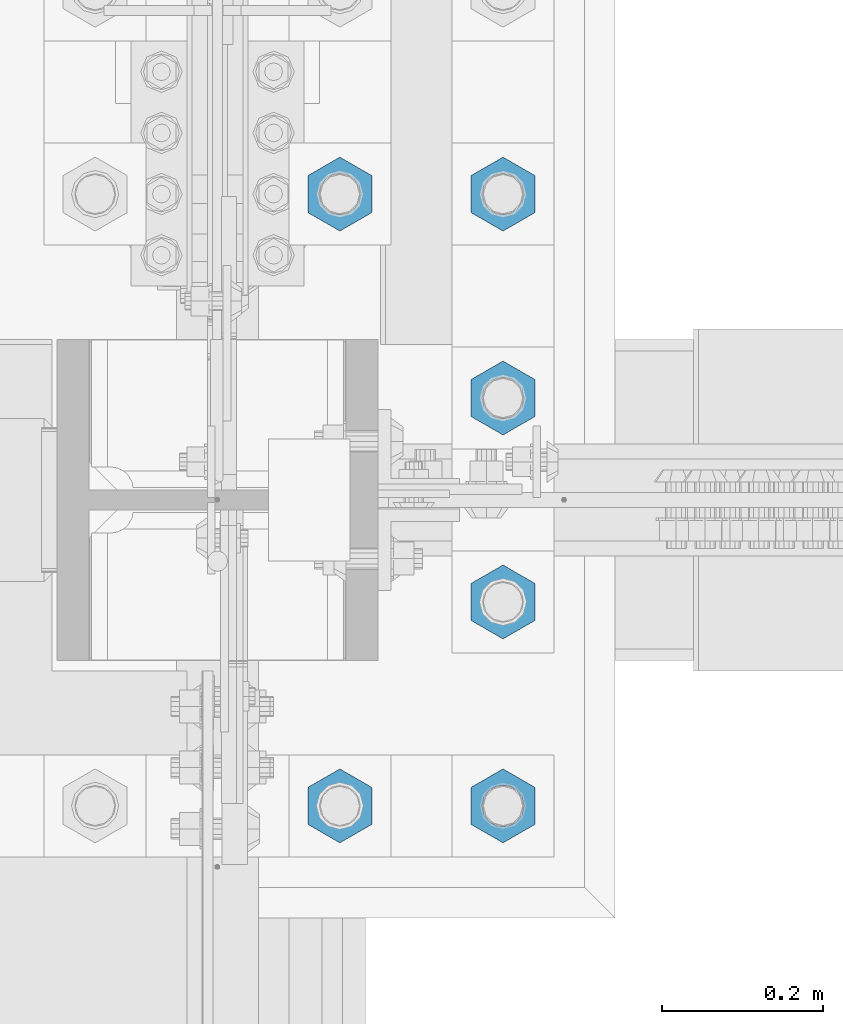
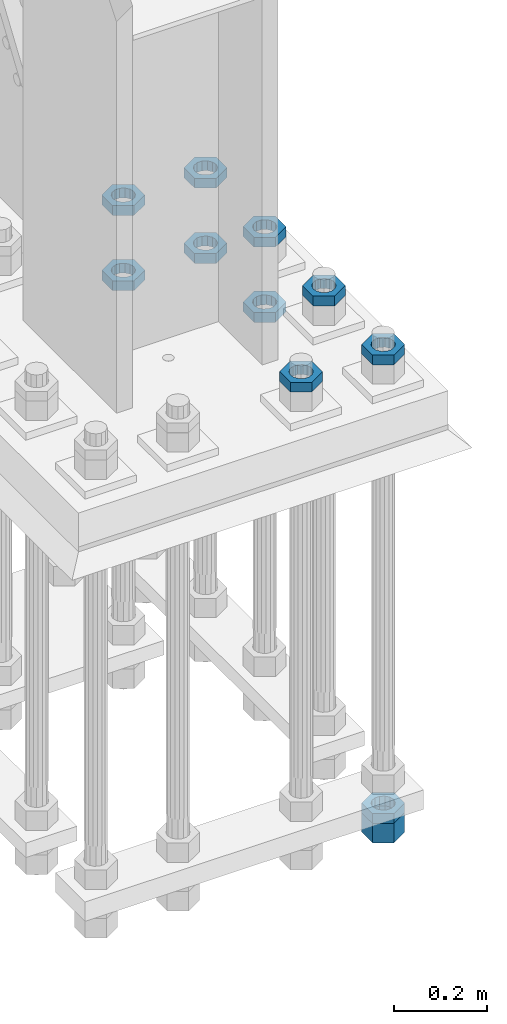
# One storey, part 2368 of 3843: 11 beams, 1 element without a shape of its own.
"""IFC2X3 building model written with IfcOpenShell, lengths in millimetres."""

from ifc_helpers import new_model, si_unit, frame, origin_with_axes, place, context, subcontext, project, spatial, faceted_brep, material, type_object, element, aggregate, save


model = new_model("IFC2X3")

# Units and contexts
model_context = context("Model", 3, precision=1e-05, world=origin_with_axes())
body_context = subcontext(model_context, "Body", "Model", "MODEL_VIEW")
ifc_project = project(units=[si_unit("LENGTHUNIT", "METRE", prefix="MILLI"), si_unit("AREAUNIT", "SQUARE_METRE"), si_unit("VOLUMEUNIT", "CUBIC_METRE"), si_unit("MASSUNIT", "GRAM", prefix="KILO"), si_unit("TIMEUNIT", "SECOND"), si_unit("PLANEANGLEUNIT", "RADIAN"), si_unit("SOLIDANGLEUNIT", "STERADIAN"), si_unit("THERMODYNAMICTEMPERATUREUNIT", "DEGREE_CELSIUS"), si_unit("LUMINOUSINTENSITYUNIT", "LUMEN")], contexts=[model_context])

# Site, building, storey
site_placement = place(None, origin_with_axes())
site = spatial("IfcSite", under=ifc_project, at=site_placement, CompositionType="ELEMENT")
building_placement = place(site_placement, origin_with_axes())
building = spatial("IfcBuilding", under=site, at=building_placement, Name="Undefined", CompositionType="ELEMENT")
storey_placement = place(building_placement, origin_with_axes())
storey = spatial("IfcBuildingStorey", under=building, at=storey_placement, Name="Undefined", CompositionType="ELEMENT", Elevation=0.0)

# Assembly, beams
assembly_placement = place(storey_placement, origin_with_axes())
assembly = element("IfcElementAssembly", 1, at=assembly_placement, inside=storey, Name="TEMPLATE", AssemblyPlace="NOTDEFINED", PredefinedType="RIGID_FRAME")
ifc_material = material(Name="STEEL/A572-50")
beam_type_1 = type_object("IfcBeamType", Name="2_HALF_NUT", PredefinedType="NOTDEFINED")
beam_1_placement = place(assembly_placement, frame((36931.6, 67398.9, 30060.9), z_axis=(-1.0, 0.0, 0.0), x_axis=(0.0, 0.0, -1.0)))
beam_1 = element("IfcBeam", 2, at=beam_1_placement, type_object=beam_type_1, material=ifc_material, Name="NUT", ObjectType="2_HALF_NUT", context=body_context, shape_type="Brep", body=[
    faceted_brep([(0.0, -46.0369987487793, 0.0), (0.0, -23.0184993743896, -39.869213104248), (25.4000000000015, -23.0184993743896, -39.869213104248), (25.4000000000015, -46.0369987487793, 0.0), (0.0, 23.0184993743896, -39.869213104248), (25.4000000000015, 23.0184993743896, -39.869213104248), (0.0, 46.0369987487793, 0.0), (25.4000000000015, 46.0369987487793, 0.0), (0.0, 23.0184993743896, 39.869213104248), (25.4000000000015, 23.0184993743896, 39.869213104248), (0.0, -23.0184993743896, 39.869213104248), (25.4000000000015, -23.0184993743896, 39.869213104248), (0.0, 0.0, 26.1940002441406), (0.0, 11.3650617044477, 23.5999013092805), (25.4000000000015, 11.3650617044477, 23.5999013092805), (25.4000000000015, 0.0, 26.1940002441406), (0.0, 20.4791109456419, 16.3316083006721), (25.4000000000015, 20.4791109456419, 16.3316083006721), (0.0, 25.5370200498292, 5.82867859874386), (25.4000000000015, 25.5370200498292, 5.82867859874386), (0.0, 25.5370200498292, -5.82867859874386), (25.4000000000015, 25.5370200498292, -5.82867859874386), (0.0, 20.4791109456419, -16.3316083006721), (25.4000000000015, 20.4791109456419, -16.3316083006721), (0.0, 11.3650617044477, -23.5999013092805), (25.4000000000015, 11.3650617044477, -23.5999013092805), (0.0, 0.0, -26.1940002441406), (25.4000000000015, 0.0, -26.1940002441406), (0.0, -11.3650617044477, -23.5999013092805), (25.4000000000015, -11.3650617044477, -23.5999013092805), (0.0, -20.4791109456419, -16.3316083006721), (25.4000000000015, -20.4791109456419, -16.3316083006721), (0.0, -25.5370200498292, -5.82867859874386), (25.4000000000015, -25.5370200498292, -5.82867859874386), (0.0, -25.5370200498292, 5.82867859874386), (25.4000000000015, -25.5370200498292, 5.82867859874386), (0.0, -20.4791109456419, 16.3316083006721), (25.4000000000015, -20.4791109456419, 16.3316083006721), (0.0, -11.3650617044477, 23.5999013092805), (25.4000000000015, -11.3650617044477, 23.5999013092805)], [[[0, 1, 2, 3]], [[1, 4, 5, 2]], [[4, 6, 7, 5]], [[6, 8, 9, 7]], [[8, 10, 11, 9]], [[10, 0, 3, 11]], [[12, 13, 14, 15]], [[13, 16, 17, 14]], [[16, 18, 19, 17]], [[18, 20, 21, 19]], [[20, 22, 23, 21]], [[22, 24, 25, 23]], [[24, 26, 27, 25]], [[26, 28, 29, 27]], [[28, 30, 31, 29]], [[30, 32, 33, 31]], [[32, 34, 35, 33]], [[34, 36, 37, 35]], [[36, 38, 39, 37]], [[38, 12, 15, 39]], [[5, 7, 9, 11, 3, 2], [17, 19, 21, 23, 25, 27, 29, 31, 33, 35, 37, 39, 15, 14]], [[10, 8, 6, 4, 1, 0], [38, 36, 34, 32, 30, 28, 26, 24, 22, 20, 18, 16, 13, 12]]]),
])
beam_2_placement = place(assembly_placement, frame((36931.6, 67652.9, 30060.9), z_axis=(1.0, 0.0, 0.0), x_axis=(0.0, 0.0, -1.0)))
beam_2 = element("IfcBeam", 3, at=beam_2_placement, type_object=beam_type_1, material=ifc_material, Name="NUT", ObjectType="2_HALF_NUT", context=body_context, shape_type="Brep", body=[
    faceted_brep([(0.0, -46.0369987487793, 0.0), (0.0, -23.0184993743896, -39.869213104248), (25.4000000000015, -23.0184993743896, -39.869213104248), (25.4000000000015, -46.0369987487793, 0.0), (0.0, 23.0184993743896, -39.869213104248), (25.4000000000015, 23.0184993743896, -39.869213104248), (0.0, 46.0369987487793, 0.0), (25.4000000000015, 46.0369987487793, 0.0), (0.0, 23.0184993743896, 39.869213104248), (25.4000000000015, 23.0184993743896, 39.869213104248), (0.0, -23.0184993743896, 39.869213104248), (25.4000000000015, -23.0184993743896, 39.869213104248), (0.0, 0.0, 26.1940002441406), (0.0, 11.3650617044477, 23.5999013092805), (25.4000000000015, 11.3650617044477, 23.5999013092805), (25.4000000000015, 0.0, 26.1940002441406), (0.0, 20.4791109456419, 16.3316083006721), (25.4000000000015, 20.4791109456419, 16.3316083006721), (0.0, 25.5370200498292, 5.82867859874386), (25.4000000000015, 25.5370200498292, 5.82867859874386), (0.0, 25.5370200498292, -5.82867859874386), (25.4000000000015, 25.5370200498292, -5.82867859874386), (0.0, 20.4791109456419, -16.3316083006721), (25.4000000000015, 20.4791109456419, -16.3316083006721), (0.0, 11.3650617044477, -23.5999013092805), (25.4000000000015, 11.3650617044477, -23.5999013092805), (0.0, 0.0, -26.1940002441406), (25.4000000000015, 0.0, -26.1940002441406), (0.0, -11.3650617044477, -23.5999013092805), (25.4000000000015, -11.3650617044477, -23.5999013092805), (0.0, -20.4791109456419, -16.3316083006721), (25.4000000000015, -20.4791109456419, -16.3316083006721), (0.0, -25.5370200498292, -5.82867859874386), (25.4000000000015, -25.5370200498292, -5.82867859874386), (0.0, -25.5370200498292, 5.82867859874386), (25.4000000000015, -25.5370200498292, 5.82867859874386), (0.0, -20.4791109456419, 16.3316083006721), (25.4000000000015, -20.4791109456419, 16.3316083006721), (0.0, -11.3650617044477, 23.5999013092805), (25.4000000000015, -11.3650617044477, 23.5999013092805)], [[[0, 1, 2, 3]], [[1, 4, 5, 2]], [[4, 6, 7, 5]], [[6, 8, 9, 7]], [[8, 10, 11, 9]], [[10, 0, 3, 11]], [[12, 13, 14, 15]], [[13, 16, 17, 14]], [[16, 18, 19, 17]], [[18, 20, 21, 19]], [[20, 22, 23, 21]], [[22, 24, 25, 23]], [[24, 26, 27, 25]], [[26, 28, 29, 27]], [[28, 30, 31, 29]], [[30, 32, 33, 31]], [[32, 34, 35, 33]], [[34, 36, 37, 35]], [[36, 38, 39, 37]], [[38, 12, 15, 39]], [[5, 7, 9, 11, 3, 2], [17, 19, 21, 23, 25, 27, 29, 31, 33, 35, 37, 39, 15, 14]], [[10, 8, 6, 4, 1, 0], [38, 36, 34, 32, 30, 28, 26, 24, 22, 20, 18, 16, 13, 12]]]),
])
beam_3_placement = place(assembly_placement, frame((36728.4, 67652.9, 30060.9), z_axis=(1.0, 0.0, 0.0), x_axis=(0.0, 0.0, -1.0)))
beam_3 = element("IfcBeam", 4, at=beam_3_placement, type_object=beam_type_1, material=ifc_material, Name="NUT", ObjectType="2_HALF_NUT", context=body_context, shape_type="Brep", body=[
    faceted_brep([(0.0, -46.0369987487793, 0.0), (0.0, -23.0184993743896, -39.869213104248), (25.4000000000015, -23.0184993743896, -39.869213104248), (25.4000000000015, -46.0369987487793, 0.0), (0.0, 23.0184993743896, -39.869213104248), (25.4000000000015, 23.0184993743896, -39.869213104248), (0.0, 46.0369987487793, 0.0), (25.4000000000015, 46.0369987487793, 0.0), (0.0, 23.0184993743896, 39.869213104248), (25.4000000000015, 23.0184993743896, 39.869213104248), (0.0, -23.0184993743896, 39.869213104248), (25.4000000000015, -23.0184993743896, 39.869213104248), (0.0, 0.0, 26.1940002441406), (0.0, 11.3650617044477, 23.5999013092805), (25.4000000000015, 11.3650617044477, 23.5999013092805), (25.4000000000015, 0.0, 26.1940002441406), (0.0, 20.4791109456419, 16.3316083006721), (25.4000000000015, 20.4791109456419, 16.3316083006721), (0.0, 25.5370200498292, 5.82867859874386), (25.4000000000015, 25.5370200498292, 5.82867859874386), (0.0, 25.5370200498292, -5.82867859874386), (25.4000000000015, 25.5370200498292, -5.82867859874386), (0.0, 20.4791109456419, -16.3316083006721), (25.4000000000015, 20.4791109456419, -16.3316083006721), (0.0, 11.3650617044477, -23.5999013092805), (25.4000000000015, 11.3650617044477, -23.5999013092805), (0.0, 0.0, -26.1940002441406), (25.4000000000015, 0.0, -26.1940002441406), (0.0, -11.3650617044477, -23.5999013092805), (25.4000000000015, -11.3650617044477, -23.5999013092805), (0.0, -20.4791109456419, -16.3316083006721), (25.4000000000015, -20.4791109456419, -16.3316083006721), (0.0, -25.5370200498292, -5.82867859874386), (25.4000000000015, -25.5370200498292, -5.82867859874386), (0.0, -25.5370200498292, 5.82867859874386), (25.4000000000015, -25.5370200498292, 5.82867859874386), (0.0, -20.4791109456419, 16.3316083006721), (25.4000000000015, -20.4791109456419, 16.3316083006721), (0.0, -11.3650617044477, 23.5999013092805), (25.4000000000015, -11.3650617044477, 23.5999013092805)], [[[0, 1, 2, 3]], [[1, 4, 5, 2]], [[4, 6, 7, 5]], [[6, 8, 9, 7]], [[8, 10, 11, 9]], [[10, 0, 3, 11]], [[12, 13, 14, 15]], [[13, 16, 17, 14]], [[16, 18, 19, 17]], [[18, 20, 21, 19]], [[20, 22, 23, 21]], [[22, 24, 25, 23]], [[24, 26, 27, 25]], [[26, 28, 29, 27]], [[28, 30, 31, 29]], [[30, 32, 33, 31]], [[32, 34, 35, 33]], [[34, 36, 37, 35]], [[36, 38, 39, 37]], [[38, 12, 15, 39]], [[5, 7, 9, 11, 3, 2], [17, 19, 21, 23, 25, 27, 29, 31, 33, 35, 37, 39, 15, 14]], [[10, 8, 6, 4, 1, 0], [38, 36, 34, 32, 30, 28, 26, 24, 22, 20, 18, 16, 13, 12]]]),
])
beam_4_placement = place(assembly_placement, frame((36931.6, 67398.9, 30257.75), z_axis=(1.0, 0.0, 0.0), x_axis=(0.0, 0.0, -1.0)))
beam_4 = element("IfcBeam", 5, at=beam_4_placement, type_object=beam_type_1, material=ifc_material, Name="NUT", ObjectType="2_HALF_NUT", context=body_context, shape_type="Brep", body=[
    faceted_brep([(0.0, -46.0369987487793, 0.0), (0.0, -23.0184993743896, -39.869213104248), (25.4000000000015, -23.0184993743896, -39.869213104248), (25.4000000000015, -46.0369987487793, 0.0), (0.0, 23.0184993743896, -39.869213104248), (25.4000000000015, 23.0184993743896, -39.869213104248), (0.0, 46.0369987487793, 0.0), (25.4000000000015, 46.0369987487793, 0.0), (0.0, 23.0184993743896, 39.869213104248), (25.4000000000015, 23.0184993743896, 39.869213104248), (0.0, -23.0184993743896, 39.869213104248), (25.4000000000015, -23.0184993743896, 39.869213104248), (0.0, 0.0, 26.1940002441406), (0.0, 11.3650617044477, 23.5999013092805), (25.4000000000015, 11.3650617044477, 23.5999013092805), (25.4000000000015, 0.0, 26.1940002441406), (0.0, 20.4791109456419, 16.3316083006721), (25.4000000000015, 20.4791109456419, 16.3316083006721), (0.0, 25.5370200498292, 5.82867859874386), (25.4000000000015, 25.5370200498292, 5.82867859874386), (0.0, 25.5370200498292, -5.82867859874386), (25.4000000000015, 25.5370200498292, -5.82867859874386), (0.0, 20.4791109456419, -16.3316083006721), (25.4000000000015, 20.4791109456419, -16.3316083006721), (0.0, 11.3650617044477, -23.5999013092805), (25.4000000000015, 11.3650617044477, -23.5999013092805), (0.0, 0.0, -26.1940002441406), (25.4000000000015, 0.0, -26.1940002441406), (0.0, -11.3650617044477, -23.5999013092805), (25.4000000000015, -11.3650617044477, -23.5999013092805), (0.0, -20.4791109456419, -16.3316083006721), (25.4000000000015, -20.4791109456419, -16.3316083006721), (0.0, -25.5370200498292, -5.82867859874386), (25.4000000000015, -25.5370200498292, -5.82867859874386), (0.0, -25.5370200498292, 5.82867859874386), (25.4000000000015, -25.5370200498292, 5.82867859874386), (0.0, -20.4791109456419, 16.3316083006721), (25.4000000000015, -20.4791109456419, 16.3316083006721), (0.0, -11.3650617044477, 23.5999013092805), (25.4000000000015, -11.3650617044477, 23.5999013092805)], [[[0, 1, 2, 3]], [[1, 4, 5, 2]], [[4, 6, 7, 5]], [[6, 8, 9, 7]], [[8, 10, 11, 9]], [[10, 0, 3, 11]], [[12, 13, 14, 15]], [[13, 16, 17, 14]], [[16, 18, 19, 17]], [[18, 20, 21, 19]], [[20, 22, 23, 21]], [[22, 24, 25, 23]], [[24, 26, 27, 25]], [[26, 28, 29, 27]], [[28, 30, 31, 29]], [[30, 32, 33, 31]], [[32, 34, 35, 33]], [[34, 36, 37, 35]], [[36, 38, 39, 37]], [[38, 12, 15, 39]], [[5, 7, 9, 11, 3, 2], [17, 19, 21, 23, 25, 27, 29, 31, 33, 35, 37, 39, 15, 14]], [[10, 8, 6, 4, 1, 0], [38, 36, 34, 32, 30, 28, 26, 24, 22, 20, 18, 16, 13, 12]]]),
])
beam_5_placement = place(assembly_placement, frame((36931.6, 67144.9, 30257.75), z_axis=(1.0, 0.0, 0.0), x_axis=(0.0, 0.0, -1.0)))
beam_5 = element("IfcBeam", 6, at=beam_5_placement, type_object=beam_type_1, material=ifc_material, Name="NUT", ObjectType="2_HALF_NUT", context=body_context, shape_type="Brep", body=[
    faceted_brep([(0.0, -46.0369987487793, 0.0), (0.0, -23.0184993743896, -39.869213104248), (25.4000000000015, -23.0184993743896, -39.869213104248), (25.4000000000015, -46.0369987487793, 0.0), (0.0, 23.0184993743896, -39.869213104248), (25.4000000000015, 23.0184993743896, -39.869213104248), (0.0, 46.0369987487793, 0.0), (25.4000000000015, 46.0369987487793, 0.0), (0.0, 23.0184993743896, 39.869213104248), (25.4000000000015, 23.0184993743896, 39.869213104248), (0.0, -23.0184993743896, 39.869213104248), (25.4000000000015, -23.0184993743896, 39.869213104248), (0.0, 0.0, 26.1940002441406), (0.0, 11.3650617044477, 23.5999013092805), (25.4000000000015, 11.3650617044477, 23.5999013092805), (25.4000000000015, 0.0, 26.1940002441406), (0.0, 20.4791109456419, 16.3316083006721), (25.4000000000015, 20.4791109456419, 16.3316083006721), (0.0, 25.5370200498292, 5.82867859874386), (25.4000000000015, 25.5370200498292, 5.82867859874386), (0.0, 25.5370200498292, -5.82867859874386), (25.4000000000015, 25.5370200498292, -5.82867859874386), (0.0, 20.4791109456419, -16.3316083006721), (25.4000000000015, 20.4791109456419, -16.3316083006721), (0.0, 11.3650617044477, -23.5999013092805), (25.4000000000015, 11.3650617044477, -23.5999013092805), (0.0, 0.0, -26.1940002441406), (25.4000000000015, 0.0, -26.1940002441406), (0.0, -11.3650617044477, -23.5999013092805), (25.4000000000015, -11.3650617044477, -23.5999013092805), (0.0, -20.4791109456419, -16.3316083006721), (25.4000000000015, -20.4791109456419, -16.3316083006721), (0.0, -25.5370200498292, -5.82867859874386), (25.4000000000015, -25.5370200498292, -5.82867859874386), (0.0, -25.5370200498292, 5.82867859874386), (25.4000000000015, -25.5370200498292, 5.82867859874386), (0.0, -20.4791109456419, 16.3316083006721), (25.4000000000015, -20.4791109456419, 16.3316083006721), (0.0, -11.3650617044477, 23.5999013092805), (25.4000000000015, -11.3650617044477, 23.5999013092805)], [[[0, 1, 2, 3]], [[1, 4, 5, 2]], [[4, 6, 7, 5]], [[6, 8, 9, 7]], [[8, 10, 11, 9]], [[10, 0, 3, 11]], [[12, 13, 14, 15]], [[13, 16, 17, 14]], [[16, 18, 19, 17]], [[18, 20, 21, 19]], [[20, 22, 23, 21]], [[22, 24, 25, 23]], [[24, 26, 27, 25]], [[26, 28, 29, 27]], [[28, 30, 31, 29]], [[30, 32, 33, 31]], [[32, 34, 35, 33]], [[34, 36, 37, 35]], [[36, 38, 39, 37]], [[38, 12, 15, 39]], [[5, 7, 9, 11, 3, 2], [17, 19, 21, 23, 25, 27, 29, 31, 33, 35, 37, 39, 15, 14]], [[10, 8, 6, 4, 1, 0], [38, 36, 34, 32, 30, 28, 26, 24, 22, 20, 18, 16, 13, 12]]]),
])
beam_6_placement = place(assembly_placement, frame((36728.4, 67652.9, 30257.75), z_axis=(-1.0, 0.0, 0.0), x_axis=(0.0, 0.0, -1.0)))
beam_6 = element("IfcBeam", 7, at=beam_6_placement, type_object=beam_type_1, material=ifc_material, Name="NUT", ObjectType="2_HALF_NUT", context=body_context, shape_type="Brep", body=[
    faceted_brep([(0.0, -46.0369987487793, 0.0), (0.0, -23.0184993743896, -39.869213104248), (25.4000000000015, -23.0184993743896, -39.869213104248), (25.4000000000015, -46.0369987487793, 0.0), (0.0, 23.0184993743896, -39.869213104248), (25.4000000000015, 23.0184993743896, -39.869213104248), (0.0, 46.0369987487793, 0.0), (25.4000000000015, 46.0369987487793, 0.0), (0.0, 23.0184993743896, 39.869213104248), (25.4000000000015, 23.0184993743896, 39.869213104248), (0.0, -23.0184993743896, 39.869213104248), (25.4000000000015, -23.0184993743896, 39.869213104248), (0.0, 0.0, 26.1940002441406), (0.0, 11.3650617044477, 23.5999013092805), (25.4000000000015, 11.3650617044477, 23.5999013092805), (25.4000000000015, 0.0, 26.1940002441406), (0.0, 20.4791109456419, 16.3316083006721), (25.4000000000015, 20.4791109456419, 16.3316083006721), (0.0, 25.5370200498292, 5.82867859874386), (25.4000000000015, 25.5370200498292, 5.82867859874386), (0.0, 25.5370200498292, -5.82867859874386), (25.4000000000015, 25.5370200498292, -5.82867859874386), (0.0, 20.4791109456419, -16.3316083006721), (25.4000000000015, 20.4791109456419, -16.3316083006721), (0.0, 11.3650617044477, -23.5999013092805), (25.4000000000015, 11.3650617044477, -23.5999013092805), (0.0, 0.0, -26.1940002441406), (25.4000000000015, 0.0, -26.1940002441406), (0.0, -11.3650617044477, -23.5999013092805), (25.4000000000015, -11.3650617044477, -23.5999013092805), (0.0, -20.4791109456419, -16.3316083006721), (25.4000000000015, -20.4791109456419, -16.3316083006721), (0.0, -25.5370200498292, -5.82867859874386), (25.4000000000015, -25.5370200498292, -5.82867859874386), (0.0, -25.5370200498292, 5.82867859874386), (25.4000000000015, -25.5370200498292, 5.82867859874386), (0.0, -20.4791109456419, 16.3316083006721), (25.4000000000015, -20.4791109456419, 16.3316083006721), (0.0, -11.3650617044477, 23.5999013092805), (25.4000000000015, -11.3650617044477, 23.5999013092805)], [[[0, 1, 2, 3]], [[1, 4, 5, 2]], [[4, 6, 7, 5]], [[6, 8, 9, 7]], [[8, 10, 11, 9]], [[10, 0, 3, 11]], [[12, 13, 14, 15]], [[13, 16, 17, 14]], [[16, 18, 19, 17]], [[18, 20, 21, 19]], [[20, 22, 23, 21]], [[22, 24, 25, 23]], [[24, 26, 27, 25]], [[26, 28, 29, 27]], [[28, 30, 31, 29]], [[30, 32, 33, 31]], [[32, 34, 35, 33]], [[34, 36, 37, 35]], [[36, 38, 39, 37]], [[38, 12, 15, 39]], [[5, 7, 9, 11, 3, 2], [17, 19, 21, 23, 25, 27, 29, 31, 33, 35, 37, 39, 15, 14]], [[10, 8, 6, 4, 1, 0], [38, 36, 34, 32, 30, 28, 26, 24, 22, 20, 18, 16, 13, 12]]]),
])
beam_7_placement = place(assembly_placement, frame((36931.6, 67652.9, 30257.75), z_axis=(-1.0, 0.0, 0.0), x_axis=(0.0, 0.0, -1.0)))
beam_7 = element("IfcBeam", 8, at=beam_7_placement, type_object=beam_type_1, material=ifc_material, Name="NUT", ObjectType="2_HALF_NUT", context=body_context, shape_type="Brep", body=[
    faceted_brep([(0.0, -46.0369987487793, 0.0), (0.0, -23.0184993743896, -39.869213104248), (25.4000000000015, -23.0184993743896, -39.869213104248), (25.4000000000015, -46.0369987487793, 0.0), (0.0, 23.0184993743896, -39.869213104248), (25.4000000000015, 23.0184993743896, -39.869213104248), (0.0, 46.0369987487793, 0.0), (25.4000000000015, 46.0369987487793, 0.0), (0.0, 23.0184993743896, 39.869213104248), (25.4000000000015, 23.0184993743896, 39.869213104248), (0.0, -23.0184993743896, 39.869213104248), (25.4000000000015, -23.0184993743896, 39.869213104248), (0.0, 0.0, 26.1940002441406), (0.0, 11.3650617044477, 23.5999013092805), (25.4000000000015, 11.3650617044477, 23.5999013092805), (25.4000000000015, 0.0, 26.1940002441406), (0.0, 20.4791109456419, 16.3316083006721), (25.4000000000015, 20.4791109456419, 16.3316083006721), (0.0, 25.5370200498292, 5.82867859874386), (25.4000000000015, 25.5370200498292, 5.82867859874386), (0.0, 25.5370200498292, -5.82867859874386), (25.4000000000015, 25.5370200498292, -5.82867859874386), (0.0, 20.4791109456419, -16.3316083006721), (25.4000000000015, 20.4791109456419, -16.3316083006721), (0.0, 11.3650617044477, -23.5999013092805), (25.4000000000015, 11.3650617044477, -23.5999013092805), (0.0, 0.0, -26.1940002441406), (25.4000000000015, 0.0, -26.1940002441406), (0.0, -11.3650617044477, -23.5999013092805), (25.4000000000015, -11.3650617044477, -23.5999013092805), (0.0, -20.4791109456419, -16.3316083006721), (25.4000000000015, -20.4791109456419, -16.3316083006721), (0.0, -25.5370200498292, -5.82867859874386), (25.4000000000015, -25.5370200498292, -5.82867859874386), (0.0, -25.5370200498292, 5.82867859874386), (25.4000000000015, -25.5370200498292, 5.82867859874386), (0.0, -20.4791109456419, 16.3316083006721), (25.4000000000015, -20.4791109456419, 16.3316083006721), (0.0, -11.3650617044477, 23.5999013092805), (25.4000000000015, -11.3650617044477, 23.5999013092805)], [[[0, 1, 2, 3]], [[1, 4, 5, 2]], [[4, 6, 7, 5]], [[6, 8, 9, 7]], [[8, 10, 11, 9]], [[10, 0, 3, 11]], [[12, 13, 14, 15]], [[13, 16, 17, 14]], [[16, 18, 19, 17]], [[18, 20, 21, 19]], [[20, 22, 23, 21]], [[22, 24, 25, 23]], [[24, 26, 27, 25]], [[26, 28, 29, 27]], [[28, 30, 31, 29]], [[30, 32, 33, 31]], [[32, 34, 35, 33]], [[34, 36, 37, 35]], [[36, 38, 39, 37]], [[38, 12, 15, 39]], [[5, 7, 9, 11, 3, 2], [17, 19, 21, 23, 25, 27, 29, 31, 33, 35, 37, 39, 15, 14]], [[10, 8, 6, 4, 1, 0], [38, 36, 34, 32, 30, 28, 26, 24, 22, 20, 18, 16, 13, 12]]]),
])
beam_8_placement = place(assembly_placement, frame((36728.4, 66890.9, 30257.75), z_axis=(1.0, 0.0, 0.0), x_axis=(0.0, 0.0, -1.0)))
beam_8 = element("IfcBeam", 9, at=beam_8_placement, type_object=beam_type_1, material=ifc_material, Name="NUT", ObjectType="2_HALF_NUT", context=body_context, shape_type="Brep", body=[
    faceted_brep([(0.0, -46.0369987487793, 0.0), (0.0, -23.0184993743896, -39.869213104248), (25.4000000000015, -23.0184993743896, -39.869213104248), (25.4000000000015, -46.0369987487793, 0.0), (0.0, 23.0184993743896, -39.869213104248), (25.4000000000015, 23.0184993743896, -39.869213104248), (0.0, 46.0369987487793, 0.0), (25.4000000000015, 46.0369987487793, 0.0), (0.0, 23.0184993743896, 39.869213104248), (25.4000000000015, 23.0184993743896, 39.869213104248), (0.0, -23.0184993743896, 39.869213104248), (25.4000000000015, -23.0184993743896, 39.869213104248), (0.0, 0.0, 26.1940002441406), (0.0, 11.3650617044477, 23.5999013092805), (25.4000000000015, 11.3650617044477, 23.5999013092805), (25.4000000000015, 0.0, 26.1940002441406), (0.0, 20.4791109456419, 16.3316083006721), (25.4000000000015, 20.4791109456419, 16.3316083006721), (0.0, 25.5370200498292, 5.82867859874386), (25.4000000000015, 25.5370200498292, 5.82867859874386), (0.0, 25.5370200498292, -5.82867859874386), (25.4000000000015, 25.5370200498292, -5.82867859874386), (0.0, 20.4791109456419, -16.3316083006721), (25.4000000000015, 20.4791109456419, -16.3316083006721), (0.0, 11.3650617044477, -23.5999013092805), (25.4000000000015, 11.3650617044477, -23.5999013092805), (0.0, 0.0, -26.1940002441406), (25.4000000000015, 0.0, -26.1940002441406), (0.0, -11.3650617044477, -23.5999013092805), (25.4000000000015, -11.3650617044477, -23.5999013092805), (0.0, -20.4791109456419, -16.3316083006721), (25.4000000000015, -20.4791109456419, -16.3316083006721), (0.0, -25.5370200498292, -5.82867859874386), (25.4000000000015, -25.5370200498292, -5.82867859874386), (0.0, -25.5370200498292, 5.82867859874386), (25.4000000000015, -25.5370200498292, 5.82867859874386), (0.0, -20.4791109456419, 16.3316083006721), (25.4000000000015, -20.4791109456419, 16.3316083006721), (0.0, -11.3650617044477, 23.5999013092805), (25.4000000000015, -11.3650617044477, 23.5999013092805)], [[[0, 1, 2, 3]], [[1, 4, 5, 2]], [[4, 6, 7, 5]], [[6, 8, 9, 7]], [[8, 10, 11, 9]], [[10, 0, 3, 11]], [[12, 13, 14, 15]], [[13, 16, 17, 14]], [[16, 18, 19, 17]], [[18, 20, 21, 19]], [[20, 22, 23, 21]], [[22, 24, 25, 23]], [[24, 26, 27, 25]], [[26, 28, 29, 27]], [[28, 30, 31, 29]], [[30, 32, 33, 31]], [[32, 34, 35, 33]], [[34, 36, 37, 35]], [[36, 38, 39, 37]], [[38, 12, 15, 39]], [[5, 7, 9, 11, 3, 2], [17, 19, 21, 23, 25, 27, 29, 31, 33, 35, 37, 39, 15, 14]], [[10, 8, 6, 4, 1, 0], [38, 36, 34, 32, 30, 28, 26, 24, 22, 20, 18, 16, 13, 12]]]),
])
beam_9_placement = place(assembly_placement, frame((36931.6, 66890.9, 30257.75), z_axis=(1.0, 0.0, 0.0), x_axis=(0.0, 0.0, -1.0)))
beam_9 = element("IfcBeam", 10, at=beam_9_placement, type_object=beam_type_1, material=ifc_material, Name="NUT", ObjectType="2_HALF_NUT", context=body_context, shape_type="Brep", body=[
    faceted_brep([(0.0, -46.0369987487793, 0.0), (0.0, -23.0184993743896, -39.869213104248), (25.4000000000015, -23.0184993743896, -39.869213104248), (25.4000000000015, -46.0369987487793, 0.0), (0.0, 23.0184993743896, -39.869213104248), (25.4000000000015, 23.0184993743896, -39.869213104248), (0.0, 46.0369987487793, 0.0), (25.4000000000015, 46.0369987487793, 0.0), (0.0, 23.0184993743896, 39.869213104248), (25.4000000000015, 23.0184993743896, 39.869213104248), (0.0, -23.0184993743896, 39.869213104248), (25.4000000000015, -23.0184993743896, 39.869213104248), (0.0, 0.0, 26.1940002441406), (0.0, 11.3650617044477, 23.5999013092805), (25.4000000000015, 11.3650617044477, 23.5999013092805), (25.4000000000015, 0.0, 26.1940002441406), (0.0, 20.4791109456419, 16.3316083006721), (25.4000000000015, 20.4791109456419, 16.3316083006721), (0.0, 25.5370200498292, 5.82867859874386), (25.4000000000015, 25.5370200498292, 5.82867859874386), (0.0, 25.5370200498292, -5.82867859874386), (25.4000000000015, 25.5370200498292, -5.82867859874386), (0.0, 20.4791109456419, -16.3316083006721), (25.4000000000015, 20.4791109456419, -16.3316083006721), (0.0, 11.3650617044477, -23.5999013092805), (25.4000000000015, 11.3650617044477, -23.5999013092805), (0.0, 0.0, -26.1940002441406), (25.4000000000015, 0.0, -26.1940002441406), (0.0, -11.3650617044477, -23.5999013092805), (25.4000000000015, -11.3650617044477, -23.5999013092805), (0.0, -20.4791109456419, -16.3316083006721), (25.4000000000015, -20.4791109456419, -16.3316083006721), (0.0, -25.5370200498292, -5.82867859874386), (25.4000000000015, -25.5370200498292, -5.82867859874386), (0.0, -25.5370200498292, 5.82867859874386), (25.4000000000015, -25.5370200498292, 5.82867859874386), (0.0, -20.4791109456419, 16.3316083006721), (25.4000000000015, -20.4791109456419, 16.3316083006721), (0.0, -11.3650617044477, 23.5999013092805), (25.4000000000015, -11.3650617044477, 23.5999013092805)], [[[0, 1, 2, 3]], [[1, 4, 5, 2]], [[4, 6, 7, 5]], [[6, 8, 9, 7]], [[8, 10, 11, 9]], [[10, 0, 3, 11]], [[12, 13, 14, 15]], [[13, 16, 17, 14]], [[16, 18, 19, 17]], [[18, 20, 21, 19]], [[20, 22, 23, 21]], [[22, 24, 25, 23]], [[24, 26, 27, 25]], [[26, 28, 29, 27]], [[28, 30, 31, 29]], [[30, 32, 33, 31]], [[32, 34, 35, 33]], [[34, 36, 37, 35]], [[36, 38, 39, 37]], [[38, 12, 15, 39]], [[5, 7, 9, 11, 3, 2], [17, 19, 21, 23, 25, 27, 29, 31, 33, 35, 37, 39, 15, 14]], [[10, 8, 6, 4, 1, 0], [38, 36, 34, 32, 30, 28, 26, 24, 22, 20, 18, 16, 13, 12]]]),
])
beam_10_placement = place(assembly_placement, frame((36931.6, 66890.9, 29057.6), z_axis=(1.0, 0.0, 0.0), x_axis=(0.0, 0.0, -1.0)))
beam_10 = element("IfcBeam", 11, at=beam_10_placement, type_object=beam_type_1, material=ifc_material, Name="NUT", ObjectType="2_HALF_NUT", context=body_context, shape_type="Brep", body=[
    faceted_brep([(0.0, -46.0369987487793, 0.0), (0.0, -23.0184993743896, -39.869213104248), (25.4000000000015, -23.0184993743896, -39.869213104248), (25.4000000000015, -46.0369987487793, 0.0), (0.0, 23.0184993743896, -39.869213104248), (25.4000000000015, 23.0184993743896, -39.869213104248), (0.0, 46.0369987487793, 0.0), (25.4000000000015, 46.0369987487793, 0.0), (0.0, 23.0184993743896, 39.869213104248), (25.4000000000015, 23.0184993743896, 39.869213104248), (0.0, -23.0184993743896, 39.869213104248), (25.4000000000015, -23.0184993743896, 39.869213104248), (0.0, 0.0, 26.1940002441406), (0.0, 11.3650617044477, 23.5999013092805), (25.4000000000015, 11.3650617044477, 23.5999013092805), (25.4000000000015, 0.0, 26.1940002441406), (0.0, 20.4791109456419, 16.3316083006721), (25.4000000000015, 20.4791109456419, 16.3316083006721), (0.0, 25.5370200498292, 5.82867859874386), (25.4000000000015, 25.5370200498292, 5.82867859874386), (0.0, 25.5370200498292, -5.82867859874386), (25.4000000000015, 25.5370200498292, -5.82867859874386), (0.0, 20.4791109456419, -16.3316083006721), (25.4000000000015, 20.4791109456419, -16.3316083006721), (0.0, 11.3650617044477, -23.5999013092805), (25.4000000000015, 11.3650617044477, -23.5999013092805), (0.0, 0.0, -26.1940002441406), (25.4000000000015, 0.0, -26.1940002441406), (0.0, -11.3650617044477, -23.5999013092805), (25.4000000000015, -11.3650617044477, -23.5999013092805), (0.0, -20.4791109456419, -16.3316083006721), (25.4000000000015, -20.4791109456419, -16.3316083006721), (0.0, -25.5370200498292, -5.82867859874386), (25.4000000000015, -25.5370200498292, -5.82867859874386), (0.0, -25.5370200498292, 5.82867859874386), (25.4000000000015, -25.5370200498292, 5.82867859874386), (0.0, -20.4791109456419, 16.3316083006721), (25.4000000000015, -20.4791109456419, 16.3316083006721), (0.0, -11.3650617044477, 23.5999013092805), (25.4000000000015, -11.3650617044477, 23.5999013092805)], [[[0, 1, 2, 3]], [[1, 4, 5, 2]], [[4, 6, 7, 5]], [[6, 8, 9, 7]], [[8, 10, 11, 9]], [[10, 0, 3, 11]], [[12, 13, 14, 15]], [[13, 16, 17, 14]], [[16, 18, 19, 17]], [[18, 20, 21, 19]], [[20, 22, 23, 21]], [[22, 24, 25, 23]], [[24, 26, 27, 25]], [[26, 28, 29, 27]], [[28, 30, 31, 29]], [[30, 32, 33, 31]], [[32, 34, 35, 33]], [[34, 36, 37, 35]], [[36, 38, 39, 37]], [[38, 12, 15, 39]], [[5, 7, 9, 11, 3, 2], [17, 19, 21, 23, 25, 27, 29, 31, 33, 35, 37, 39, 15, 14]], [[10, 8, 6, 4, 1, 0], [38, 36, 34, 32, 30, 28, 26, 24, 22, 20, 18, 16, 13, 12]]]),
])
beam_type_2 = type_object("IfcBeamType", Name="2_HEAVY_HEX_NUT", PredefinedType="NOTDEFINED")
beam_11_placement = place(assembly_placement, frame((36931.6, 66890.9, 29032.2), z_axis=(1.0, 0.0, 0.0), x_axis=(0.0, 0.0, -1.0)))
beam_11 = element("IfcBeam", 12, at=beam_11_placement, type_object=beam_type_2, material=ifc_material, Name="NUT", ObjectType="2_HEAVY_HEX_NUT", context=body_context, shape_type="Brep", body=[
    faceted_brep([(0.0, -46.0369987487793, 0.0), (0.0, -23.0184993743896, -39.869213104248), (50.7999999999993, -23.0184993743896, -39.869213104248), (50.7999999999993, -46.0369987487793, 0.0), (0.0, 23.0184993743896, -39.869213104248), (50.7999999999993, 23.0184993743896, -39.869213104248), (0.0, 46.0369987487793, 0.0), (50.7999999999993, 46.0369987487793, 0.0), (0.0, 23.0184993743896, 39.869213104248), (50.7999999999993, 23.0184993743896, 39.869213104248), (0.0, -23.0184993743896, 39.869213104248), (50.7999999999993, -23.0184993743896, 39.869213104248), (0.0, 0.0, 26.1940002441406), (0.0, 11.3650617044477, 23.5999013092805), (50.7999999999993, 11.3650617044477, 23.5999013092805), (50.7999999999993, 0.0, 26.1940002441406), (0.0, 20.4791109456419, 16.3316083006721), (50.7999999999993, 20.4791109456419, 16.3316083006721), (0.0, 25.5370200498292, 5.82867859874386), (50.7999999999993, 25.5370200498292, 5.82867859874386), (0.0, 25.5370200498292, -5.82867859874386), (50.7999999999993, 25.5370200498292, -5.82867859874386), (0.0, 20.4791109456419, -16.3316083006721), (50.7999999999993, 20.4791109456419, -16.3316083006721), (0.0, 11.3650617044477, -23.5999013092805), (50.7999999999993, 11.3650617044477, -23.5999013092805), (0.0, 0.0, -26.1940002441406), (50.7999999999993, 0.0, -26.1940002441406), (0.0, -11.3650617044477, -23.5999013092805), (50.7999999999993, -11.3650617044477, -23.5999013092805), (0.0, -20.4791109456419, -16.3316083006721), (50.7999999999993, -20.4791109456419, -16.3316083006721), (0.0, -25.5370200498292, -5.82867859874386), (50.7999999999993, -25.5370200498292, -5.82867859874386), (0.0, -25.5370200498292, 5.82867859874386), (50.7999999999993, -25.5370200498292, 5.82867859874386), (0.0, -20.4791109456419, 16.3316083006721), (50.7999999999993, -20.4791109456419, 16.3316083006721), (0.0, -11.3650617044477, 23.5999013092805), (50.7999999999993, -11.3650617044477, 23.5999013092805)], [[[0, 1, 2, 3]], [[1, 4, 5, 2]], [[4, 6, 7, 5]], [[6, 8, 9, 7]], [[8, 10, 11, 9]], [[10, 0, 3, 11]], [[12, 13, 14, 15]], [[13, 16, 17, 14]], [[16, 18, 19, 17]], [[18, 20, 21, 19]], [[20, 22, 23, 21]], [[22, 24, 25, 23]], [[24, 26, 27, 25]], [[26, 28, 29, 27]], [[28, 30, 31, 29]], [[30, 32, 33, 31]], [[32, 34, 35, 33]], [[34, 36, 37, 35]], [[36, 38, 39, 37]], [[38, 12, 15, 39]], [[5, 7, 9, 11, 3, 2], [17, 19, 21, 23, 25, 27, 29, 31, 33, 35, 37, 39, 15, 14]], [[10, 8, 6, 4, 1, 0], [38, 36, 34, 32, 30, 28, 26, 24, 22, 20, 18, 16, 13, 12]]]),
])
aggregate(assembly, [beam_1, beam_2, beam_3, beam_4, beam_5, beam_6, beam_7, beam_8, beam_9, beam_11, beam_10])

save(model, "model.ifc")
